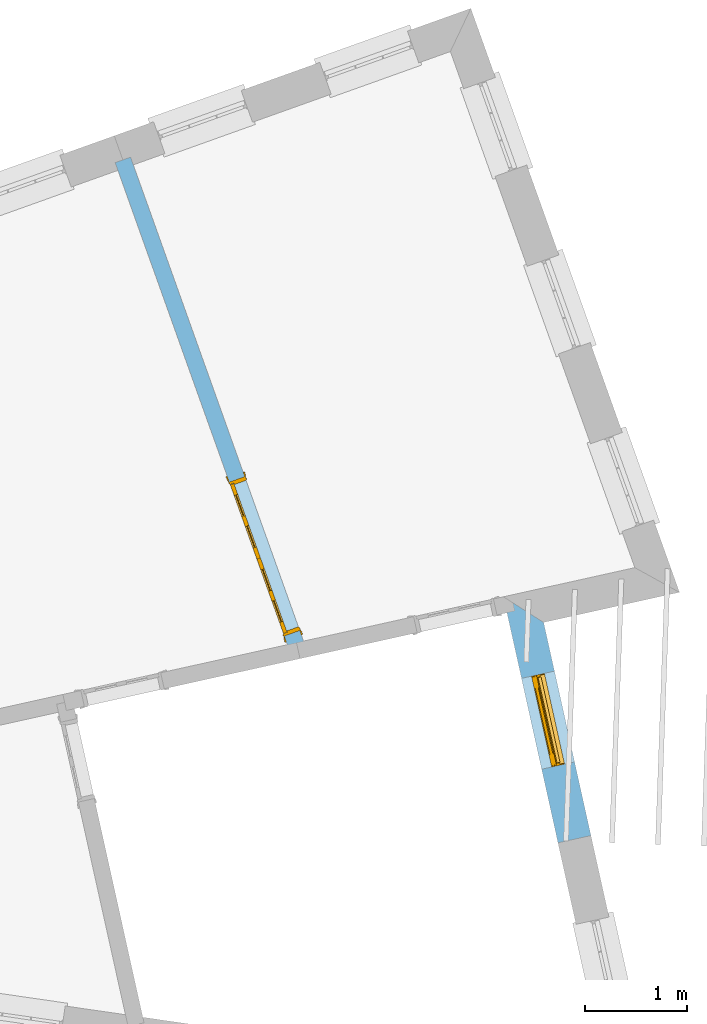
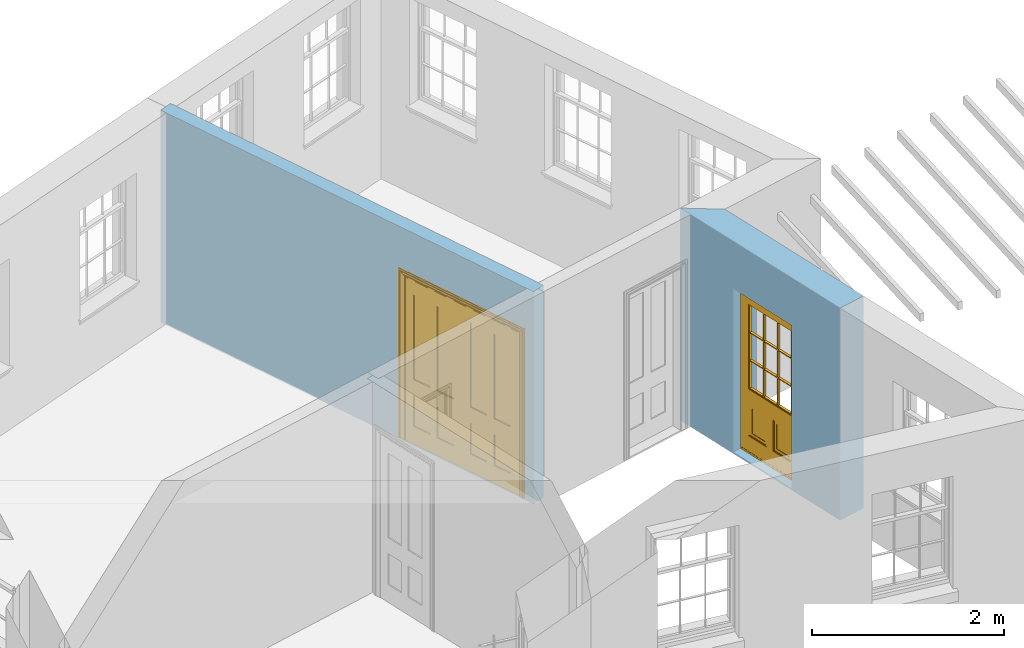
# One storey, part 7 of 11: 2 doors, 2 openings, plus 2 elements that do not belong to this part.
"""IFC2X3 building model written with IfcOpenShell, lengths in metres."""

from ifc_helpers import new_model, si_unit, frame, origin, place, context, subcontext, project, spatial, polyline, outline, extrude, faceted_brep, material, layer, layer_set, layer_usage, element, fill, save


model = new_model("IFC2X3")

# Units and contexts
model_context = context("Model", 3, world=origin())
body_context = subcontext(model_context, "Body", "Model", "MODEL_VIEW")
ifc_project = project(units=[si_unit("PLANEANGLEUNIT", "RADIAN"), si_unit("MASSUNIT", "GRAM", prefix="KILO"), si_unit("FORCEUNIT", "NEWTON", prefix="KILO"), si_unit("LENGTHUNIT", "METRE")], contexts=[model_context])

# Site, building, storey
site_placement = place(None, origin())
site = spatial("IfcSite", under=ifc_project, at=site_placement, CompositionType="ELEMENT")
building_placement = place(None, origin())
building = spatial("IfcBuilding", under=site, at=building_placement, Name="Building plot-16", CompositionType="ELEMENT")
storey_placement = place(None, frame((0.0, 0.0, 9.0)))
storey = spatial("IfcBuildingStorey", under=building, at=storey_placement, Name="Floor 2", CompositionType="ELEMENT", Elevation=9.0)

# Wall, opening, door
ifc_material_1 = material(Name="Masonry")
ifc_layer_1 = layer(ifc_material_1, 0.33, ventilated=False)
ifc_layer_set_1 = layer_set([ifc_layer_1], Name="My Wall")
ifc_layer_usage_1 = layer_usage(ifc_layer_set_1, "AXIS2", "NEGATIVE", 0.08)
wall_1_placement = place(storey_placement, origin())
wall_1 = element("IfcWallStandardCase", 1, at=wall_1_placement, inside=storey, material=ifc_layer_usage_1, Name="exterior", context=body_context, shape_type="SweptSolid", body=[
    extrude(outline(polyline([(96.6294918891393, 33.110627952855), (96.9516649800753, 33.1820737328336), (96.4893931799692, 35.2666130119531), (96.0957743090546, 35.5173403229106), (96.6294918891393, 33.110627952855)])), origin(), (0.0, 0.0, 1.0), 2.7),
])
opening_1_placement = place(storey_placement, frame((0.0, 0.0, 0.0199999999999996)))
opening_1 = element("IfcOpeningElement", 2, at=opening_1_placement, cuts=wall_1, Name="Opening", ObjectType="Opening", context=body_context, shape_type="SweptSolid", body=[
    extrude(outline(polyline([(96.7919748600008, 33.9021702814574), (96.5949577091508, 34.7905869867657), (96.2727846182148, 34.7191412067871), (96.4698017690648, 33.8307245014788), (96.7919748600008, 33.9021702814574)])), origin(), (0.0, 0.0, 1.0), 2.08),
])
door_1_placement = place(storey_placement, frame((96.5479043365645, 33.8480446905645, 0.0199999999999996), z_axis=(0.0, 0.0, 1.0), x_axis=(-0.197017150850044, 0.888416705308344, 0.0)))
door_1 = element("IfcDoor", 3, at=door_1_placement, inside=storey, Name="circulation outside door", OverallHeight=2.08, OverallWidth=0.91, context=body_context, shape_type="Brep", held_by="IfcProductRepresentation", body=[
    faceted_brep([(0.545, -0.055, 0.265), (0.745, -0.055, 0.265), (0.745, -0.05, 0.265), (0.545, -0.05, 0.265), (0.745, -0.05, 0.58), (0.545, -0.05, 0.58), (0.545, -0.055, 0.58), (0.515, -0.06, 0.235), (0.775, -0.06, 0.235), (0.745, -0.055, 0.58), (0.515, -0.06, 0.61), (0.515, -0.065, 0.235), (0.775, -0.065, 0.235), (0.775, -0.06, 0.61), (0.515, -0.065, 0.61), (0.785, -0.065, 0.225), (0.505, -0.065, 0.225), (0.775, -0.065, 0.61), (0.505, -0.065, 0.62), (0.785, -0.065, 0.62), (0.505, -0.07, 0.225), (0.785, -0.07, 0.225), (0.505, -0.07, 0.62), (0.785, -0.07, 0.62), (0.883, -0.07, 0.075), (0.898, -0.07, 0.075), (0.405, -0.07, 0.62), (0.405, -0.07, 0.225), (0.027, -0.07, 0.075), (0.785, -0.07, 0.82), (0.125, -0.07, 0.82), (0.405, -0.065, 0.62), (0.405, -0.065, 0.225), (0.898, -0.07, 2.068), (0.027, -0.08, 0.075), (0.883, -0.08, 0.075), (0.125, -0.07, 0.225), (0.012, -0.07, 0.075), (0.785, -0.06, 0.82), (0.125, -0.06, 0.82), (0.125, -0.07, 0.62), (0.125, -0.065, 0.62), (0.395, -0.065, 0.61), (0.395, -0.065, 0.235), (0.125, -0.065, 0.225), (0.785, -0.07, 1.895), (0.027, -0.11, 0.045), (0.883, -0.11, 0.045), (0.558333, -0.06, 0.83), (0.351667, -0.06, 0.83), (0.125, -0.07, 1.895), (0.125, -0.06, 1.895), (0.785, -0.06, 1.895), (0.012, -0.07, 2.068), (0.135, -0.065, 0.61), (0.395, -0.06, 0.61), (0.395, -0.06, 0.235), (0.135, -0.065, 0.235), (0.027, -0.11, 0.027), (0.883, -0.11, 0.027), (0.568333, -0.06, 0.83), (0.558333, -0.03, 0.83), (0.351667, -0.03, 0.83), (0.341667, -0.06, 0.83), (0.135, -0.06, 1.185), (0.135, -0.06, 1.53), (0.775, -0.06, 1.53), (0.775, -0.06, 1.185), (0.135, -0.06, 0.61), (0.365, -0.055, 0.58), (0.365, -0.055, 0.265), (0.135, -0.06, 0.235), (0.568333, -0.06, 1.175), (0.558333, -0.06, 1.175), (0.775, -0.06, 0.83), (0.558333, -0.03, 1.175), (0.785, -0.03, 0.82), (0.125, -0.03, 0.82), (0.351667, -0.03, 1.175), (0.351667, -0.06, 1.175), (0.341667, -0.06, 1.175), (0.135, -0.06, 0.83), (0.135, -0.06, 1.175), (0.135, -0.03, 1.185), (0.135, -0.03, 1.53), (0.135, -0.06, 1.54), (0.351667, -0.06, 1.885), (0.558333, -0.06, 1.885), (0.775, -0.03, 1.53), (0.775, -0.03, 1.185), (0.775, -0.06, 1.175), (0.775, -0.06, 1.54), (0.165, -0.055, 0.58), (0.365, -0.05, 0.58), (0.365, -0.05, 0.265), (0.165, -0.055, 0.265), (0.568333, -0.03, 0.83), (0.568333, -0.03, 1.175), (0.568333, -0.06, 1.185), (0.558333, -0.06, 1.185), (0.775, -0.03, 0.83), (0.785, -0.02, 0.82), (0.125, -0.02, 0.82), (0.341667, -0.03, 0.83), (0.341667, -0.03, 1.175), (0.351667, -0.06, 1.185), (0.341667, -0.06, 1.185), (0.135, -0.03, 0.83), (0.341667, -0.03, 1.185), (0.125, -0.03, 1.895), (0.341667, -0.03, 1.53), (0.341667, -0.06, 1.53), (0.135, -0.06, 1.885), (0.341667, -0.06, 1.54), (0.341667, -0.06, 1.885), (0.558333, -0.03, 1.885), (0.351667, -0.03, 1.885), (0.568333, -0.06, 1.885), (0.785, -0.03, 1.895), (0.568333, -0.03, 1.185), (0.568333, -0.06, 1.53), (0.568333, -0.03, 1.53), (0.568333, -0.06, 1.54), (0.775, -0.06, 1.885), (0.165, -0.05, 0.58), (0.165, -0.05, 0.265), (0.775, -0.03, 1.175), (0.558333, -0.06, 1.53), (0.351667, -0.03, 1.185), (0.558333, -0.03, 1.185), (0.505, -0.02, 0.62), (0.405, -0.02, 0.62), (0.125, -0.02, 1.895), (0.785, -0.02, 1.895), (0.351667, -0.06, 1.53), (0.135, -0.03, 1.175), (0.135, -0.03, 1.54), (0.341667, -0.03, 1.54), (0.135, -0.03, 1.885), (0.351667, -0.06, 1.54), (0.558333, -0.03, 1.54), (0.558333, -0.06, 1.54), (0.351667, -0.03, 1.54), (0.775, -0.03, 1.54), (0.568333, -0.03, 1.54), (0.775, -0.03, 1.885), (0.558333, -0.03, 1.53), (0.405, -0.02, 0.225), (0.505, -0.02, 0.225), (0.125, -0.02, 0.62), (0.785, -0.02, 0.62), (0.012, -0.02, 2.068), (0.898, -0.02, 2.068), (0.351667, -0.03, 1.53), (0.341667, -0.03, 1.885), (0.568333, -0.03, 1.885), (0.405, -0.025, 0.225), (0.405, -0.025, 0.62), (0.505, -0.025, 0.62), (0.505, -0.025, 0.225), (0.898, -0.02, 0.027), (0.012, -0.02, 0.027), (0.125, -0.025, 0.62), (0.785, -0.025, 0.62), (0.395, -0.025, 0.235), (0.395, -0.025, 0.61), (0.125, -0.02, 0.225), (0.125, -0.025, 0.225), (0.515, -0.025, 0.61), (0.515, -0.025, 0.235), (0.785, -0.02, 0.225), (0.785, -0.025, 0.225), (0.135, -0.025, 0.61), (0.775, -0.025, 0.61), (0.135, -0.025, 0.235), (0.395, -0.03, 0.235), (0.395, -0.03, 0.61), (0.515, -0.03, 0.61), (0.515, -0.03, 0.235), (0.775, -0.025, 0.235), (0.135, -0.03, 0.61), (0.775, -0.03, 0.61), (0.135, -0.03, 0.235), (0.365, -0.035, 0.265), (0.365, -0.035, 0.58), (0.545, -0.035, 0.58), (0.545, -0.035, 0.265), (0.775, -0.03, 0.235), (0.165, -0.035, 0.58), (0.745, -0.035, 0.58), (0.165, -0.035, 0.265), (0.365, -0.04, 0.58), (0.365, -0.04, 0.265), (0.545, -0.04, 0.58), (0.545, -0.04, 0.265), (0.745, -0.035, 0.265), (0.165, -0.04, 0.58), (0.745, -0.04, 0.58), (0.165, -0.04, 0.265), (0.745, -0.04, 0.265), (0.885, -0.072, 0.025), (0.025, -0.072, 0.025), (0.025, -0.1, 0.025), (0.885, -0.1, 0.025), (0.9, -0.02, 0.025), (0.01, -0.02, 0.025), (0.9, -0.072, 0.025), (0.91, -0.02, 0.0), (0.0, -0.02, 0.0), (0.01, -0.072, 0.025), (0.9, -0.072, 2.07), (0.9, -0.02, 2.07), (0.885, -0.072, 2.055), (0.91, -0.02, 2.08), (0.01, -0.02, 2.07), (0.0, -0.02, 2.08), (0.01, -0.072, 2.07), (0.025, -0.072, 2.055), (0.0, -0.15, 2.08), (0.91, -0.15, 2.08), (0.01, -0.15, 2.07), (0.9, -0.15, 2.07), (0.01, -0.1, 2.07), (0.9, -0.1, 2.07), (0.0, -0.15, 0.0), (0.91, -0.15, 0.0), (0.01, -0.15, 0.025), (0.9, -0.15, 0.025), (0.01, -0.1, 0.025), (0.025, -0.1, 2.055), (0.9, -0.1, 0.025), (0.885, -0.1, 2.055), (0.898, -0.07, 0.027), (0.012, -0.07, 0.027), (0.883, -0.07, 0.027), (0.027, -0.07, 0.027)], [[[0, 1, 2, 3]], [[2, 4, 5, 3]], [[0, 3, 5, 6]], [[1, 0, 7, 8]], [[9, 4, 2, 1]], [[9, 6, 5, 4]], [[0, 6, 10, 7]], [[8, 7, 11, 12]], [[8, 13, 9, 1]], [[13, 10, 6, 9]], [[7, 10, 14, 11]], [[15, 12, 11, 16]], [[12, 17, 13, 8]], [[17, 14, 10, 13]], [[18, 16, 11, 14]], [[15, 19, 17, 12]], [[15, 16, 20, 21]], [[14, 17, 19, 18]], [[16, 18, 22, 20]], [[21, 23, 19, 15]], [[24, 25, 21, 20]], [[23, 22, 18, 19]], [[20, 22, 26, 27]], [[23, 21, 25]], [[28, 24, 20, 27]], [[22, 23, 29]], [[29, 30, 26, 22]], [[27, 26, 31, 32]], [[23, 25, 33, 29]], [[34, 35, 24, 28]], [[28, 27, 36, 37]], [[38, 39, 30, 29]], [[26, 30, 40]], [[26, 40, 41, 31]], [[42, 43, 32, 31]], [[32, 44, 36, 27]], [[33, 45, 29]], [[46, 47, 35, 34]], [[36, 40, 37]], [[39, 38, 48, 49]], [[50, 30, 39, 51]], [[29, 45, 52, 38]], [[53, 37, 40, 30]], [[44, 41, 40, 36]], [[31, 41, 54, 42]], [[43, 42, 55, 56]], [[57, 44, 32, 43]], [[50, 45, 33, 53]], [[47, 46, 58, 59]], [[60, 48, 38]], [[49, 48, 61, 62]], [[49, 63, 39]], [[50, 53, 30]], [[51, 39, 64, 65]], [[45, 50, 51, 52]], [[66, 67, 38, 52]], [[57, 54, 41, 44]], [[42, 54, 68, 55]], [[56, 55, 69, 70]], [[56, 71, 57, 43]], [[60, 72, 73, 48]], [[60, 38, 74]], [[48, 73, 75, 61]], [[76, 77, 62, 61]], [[62, 78, 79, 49]], [[49, 79, 80, 63]], [[63, 81, 39]], [[82, 64, 39]], [[65, 64, 83, 84]], [[85, 51, 65]], [[52, 51, 86, 87]], [[88, 89, 67, 66]], [[90, 38, 67]], [[91, 66, 52]], [[71, 68, 54, 57]], [[55, 68, 92, 69]], [[69, 93, 94, 70]], [[70, 95, 71, 56]], [[96, 97, 72, 60]], [[73, 72, 98, 99]], [[74, 38, 90]], [[100, 96, 60, 74]], [[75, 73, 79, 78]], [[61, 75, 97, 96]], [[101, 102, 77, 76]], [[77, 103, 62]], [[96, 76, 61]], [[103, 104, 78, 62]], [[80, 79, 105, 106]], [[63, 80, 104, 103]], [[81, 63, 103, 107]], [[81, 82, 39]], [[106, 64, 82, 80]], [[106, 108, 83, 64]], [[84, 83, 77, 109]], [[110, 111, 65, 84]], [[112, 51, 85]], [[113, 85, 65, 111]], [[114, 86, 51]], [[115, 87, 86, 116]], [[117, 52, 87]], [[118, 76, 89, 88]], [[119, 98, 67, 89]], [[120, 121, 88, 66]], [[67, 98, 72, 90]], [[91, 122, 120, 66]], [[91, 52, 123]], [[95, 92, 68, 71]], [[69, 92, 124, 93]], [[94, 93, 124, 125]], [[94, 125, 95, 70]], [[72, 97, 126, 90]], [[127, 99, 98, 120]], [[99, 105, 79, 73]], [[74, 90, 126, 100]], [[96, 100, 76]], [[128, 129, 75, 78]], [[97, 75, 129, 119]], [[130, 131, 102, 101]], [[109, 77, 102, 132]], [[133, 101, 76, 118]], [[77, 107, 103]], [[78, 104, 108, 128]], [[111, 106, 105, 134]], [[104, 80, 82, 135]], [[107, 135, 82, 81]], [[110, 108, 106, 111]], [[104, 135, 83, 108]], [[83, 135, 77]], [[136, 84, 109]], [[110, 84, 136, 137]], [[114, 51, 112]], [[85, 136, 138, 112]], [[113, 137, 136, 85]], [[111, 134, 139, 113]], [[86, 114, 113, 139]], [[140, 141, 87, 115]], [[139, 142, 116, 86]], [[109, 118, 115, 116]], [[117, 123, 52]], [[117, 87, 141, 122]], [[126, 89, 76]], [[143, 118, 88]], [[120, 98, 119, 121]], [[119, 89, 126, 97]], [[144, 143, 88, 121]], [[144, 122, 91, 143]], [[127, 120, 122, 141]], [[143, 91, 123, 145]], [[124, 92, 95, 125]], [[146, 129, 99, 127]], [[99, 129, 128, 105]], [[100, 126, 76]], [[121, 119, 129, 146]], [[147, 131, 130, 148]], [[131, 149, 102]], [[130, 101, 150]], [[102, 151, 132]], [[118, 109, 132, 133]], [[101, 133, 152]], [[107, 77, 135]], [[153, 128, 108, 110]], [[134, 105, 128, 153]], [[109, 138, 136]], [[153, 110, 137, 142]], [[154, 114, 112, 138]], [[137, 113, 114, 154]], [[141, 139, 134, 127]], [[141, 140, 142, 139]], [[144, 140, 115, 155]], [[142, 137, 154, 116]], [[155, 115, 118]], [[116, 154, 109]], [[117, 155, 145, 123]], [[122, 144, 155, 117]], [[143, 145, 118]], [[121, 146, 140, 144]], [[146, 127, 134, 153]], [[156, 157, 131, 147]], [[148, 130, 158, 159]], [[148, 160, 161, 147]], [[157, 162, 149, 131]], [[161, 151, 102, 149]], [[101, 152, 160, 150]], [[163, 158, 130, 150]], [[151, 152, 133, 132]], [[154, 138, 109]], [[142, 140, 146, 153]], [[145, 155, 118]], [[157, 156, 164, 165]], [[147, 166, 167, 156]], [[168, 169, 159, 158]], [[170, 148, 159, 171]], [[148, 170, 160]], [[166, 147, 161]], [[172, 162, 157, 165]], [[166, 149, 162, 167]], [[166, 161, 149]], [[150, 160, 170]], [[163, 173, 168, 158]], [[171, 163, 150, 170]], [[174, 164, 156, 167]], [[175, 176, 165, 164]], [[169, 168, 177, 178]], [[171, 159, 169, 179]], [[167, 162, 172, 174]], [[176, 180, 172, 165]], [[179, 173, 163, 171]], [[181, 177, 168, 173]], [[164, 174, 182, 175]], [[183, 184, 176, 175]], [[178, 177, 185, 186]], [[179, 169, 178, 187]], [[174, 172, 180, 182]], [[184, 188, 180, 176]], [[187, 181, 173, 179]], [[189, 185, 177, 181]], [[175, 182, 190, 183]], [[191, 184, 183, 192]], [[185, 193, 194, 186]], [[187, 178, 186, 195]], [[182, 180, 188, 190]], [[191, 196, 188, 184]], [[195, 189, 181, 187]], [[197, 193, 185, 189]], [[183, 190, 198, 192]], [[198, 196, 191, 192]], [[194, 193, 197, 199]], [[195, 186, 194, 199]], [[188, 196, 198, 190]], [[197, 189, 195, 199]], [[200, 201, 202, 203]], [[201, 200, 204, 205]], [[206, 204, 200]], [[204, 207, 208, 205]], [[209, 201, 205]], [[210, 211, 204, 206]], [[206, 200, 212, 210]], [[211, 213, 207, 204]], [[214, 205, 208, 215]], [[216, 217, 201, 209]], [[205, 214, 216, 209]], [[216, 214, 211, 210]], [[210, 212, 217, 216]], [[214, 215, 213, 211]], [[218, 219, 213, 215]], [[219, 218, 220, 221]], [[221, 220, 222, 223]], [[215, 208, 224, 218]], [[225, 224, 208, 207]], [[224, 226, 220, 218]], [[224, 225, 227, 226]], [[219, 225, 207, 213]], [[228, 222, 220, 226]], [[219, 221, 227, 225]], [[226, 227, 203, 202]], [[202, 229, 222, 228]], [[228, 226, 202]], [[227, 221, 223, 230]], [[230, 203, 227]], [[217, 229, 202, 201]], [[231, 223, 222, 229]], [[230, 223, 231, 203]], [[231, 229, 217, 212]], [[212, 200, 203, 231]], [[33, 152, 151, 53]], [[25, 160, 152, 33]], [[161, 37, 53, 151]], [[232, 160, 25]], [[161, 233, 37]], [[160, 232, 234]], [[24, 234, 232, 25]], [[233, 161, 235]], [[37, 233, 235, 28]], [[161, 160, 234, 235]], [[35, 47, 234, 24]], [[28, 235, 46, 34]], [[58, 235, 234, 59]], [[59, 234, 47]], [[58, 46, 235]]]),
])
fill(opening_1, door_1)

ifc_material_2 = material(Name="Masonry")
ifc_layer_2 = layer(ifc_material_2, 0.16, ventilated=False)
ifc_layer_set_2 = layer_set([ifc_layer_2], Name="My Wall")
ifc_layer_usage_2 = layer_usage(ifc_layer_set_2, "AXIS2", "NEGATIVE", 0.08)
wall_2_placement = place(storey_placement, origin())
wall_2 = element("IfcWallStandardCase", 4, at=wall_2_placement, inside=storey, material=ifc_layer_usage_2, Name="interior", context=body_context, shape_type="SweptSolid", body=[
    extrude(outline(polyline([(94.0135349523294, 34.9634200632447), (94.1642034180616, 35.0172625505007), (92.4487673338736, 39.8176002770463), (92.2980988681414, 39.7637577897903), (94.0135349523294, 34.9634200632447)])), origin(), (0.0, 0.0, 1.0), 2.7),
])
opening_2_placement = place(storey_placement, frame((0.0, 0.0, 0.0199999999999996)))
opening_2 = element("IfcOpeningElement", 5, at=opening_2_placement, cuts=wall_2, Name="Opening", ObjectType="Opening", context=body_context, shape_type="SweptSolid", body=[
    extrude(outline(polyline([(94.1036306198986, 35.1867645744494), (93.5652057473382, 36.693449231771), (93.414537281606, 36.639606744515), (93.9529621541664, 35.1329220871934), (94.1036306198986, 35.1867645744494)])), origin(), (0.0, 0.0, 1.0), 2.1),
])
door_2_placement = place(storey_placement, frame((94.0282963870325, 35.1598433308214, 0.0199999999999996), z_axis=(0.0, 0.0, 1.0), x_axis=(-0.538424872560356, 1.50668465732162, 0.0)))
door_2 = element("IfcDoor", 6, at=door_2_placement, inside=storey, Name="kitchen living inside door", OverallHeight=2.1, OverallWidth=1.6, context=body_context, shape_type="Brep", held_by="IfcProductRepresentation", body=[
    faceted_brep([(0.14, 0.057, 1.895), (0.14, 0.057, 0.82), (0.363, 0.057, 0.82), (0.363, 0.057, 1.895), (0.14, 0.042, 1.895), (0.14, 0.042, 0.82), (0.363, 0.042, 0.82), (0.363, 0.042, 1.895), (0.027, 0.042, 1.895), (0.027, 0.042, 0.82), (0.363, 0.042, 0.62), (0.14, 0.042, 0.62), (0.463, 0.042, 0.82), (0.463, 0.042, 1.895), (0.363, 0.042, 2.073), (0.14, 0.042, 2.073), (0.027, 0.042, 2.073), (0.027, 0.08, 1.895), (0.027, 0.08, 0.82), (0.027, 0.042, 0.62), (0.463, 0.042, 0.62), (0.14, 0.057, 0.62), (0.363, 0.057, 0.62), (0.463, 0.057, 0.82), (0.463, 0.057, 1.895), (0.463, 0.042, 2.073), (0.14, 0.08, 2.073), (0.363, 0.08, 2.073), (0.027, 0.08, 2.073), (0.14, 0.08, 1.895), (0.14, 0.08, 0.82), (0.027, 0.08, 0.62), (0.027, 0.042, 0.225), (0.14, 0.042, 0.225), (0.363, 0.042, 0.225), (0.463, 0.042, 0.225), (0.686, 0.042, 0.62), (0.686, 0.042, 0.82), (0.14, 0.057, 0.225), (0.363, 0.057, 0.225), (0.686, 0.057, 0.82), (0.686, 0.057, 1.895), (0.686, 0.042, 1.895), (0.686, 0.042, 2.073), (0.463, 0.08, 2.073), (0.363, 0.08, 1.895), (0.14, 0.065, 1.895), (0.14, 0.065, 0.82), (0.14, 0.08, 0.62), (0.027, 0.08, 0.225), (0.027, 0.042, 0.0), (0.14, 0.042, 0.0), (0.363, 0.042, 0.0), (0.463, 0.042, 0.0), (0.463, 0.057, 0.225), (0.463, 0.057, 0.62), (0.686, 0.057, 0.62), (0.799, 0.042, 0.62), (0.799, 0.042, 0.82), (0.799, 0.042, 1.895), (0.799, 0.042, 2.073), (0.686, 0.08, 2.073), (0.463, 0.08, 1.895), (0.363, 0.065, 1.895), (0.363, 0.065, 0.82), (0.363, 0.08, 0.82), (0.363, 0.08, 0.62), (0.14, 0.08, 0.225), (0.027, 0.08, 0.0), (0.14, 0.08, 0.0), (0.363, 0.08, 0.0), (0.463, 0.08, 0.0), (0.686, 0.042, 0.0), (0.686, 0.042, 0.225), (0.686, 0.057, 0.225), (0.799, 0.042, 0.225), (0.799, 0.08, 0.62), (0.799, 0.08, 0.82), (0.799, 0.08, 1.895), (0.799, 0.08, 2.073), (0.686, 0.08, 1.895), (0.463, 0.08, 0.82), (0.463, 0.08, 0.62), (0.363, 0.065, 0.62), (0.14, 0.065, 0.62), (0.14, 0.065, 0.225), (0.363, 0.08, 0.225), (0.463, 0.08, 0.225), (0.686, 0.08, 0.0), (0.799, 0.042, 0.0), (0.799, 0.08, 0.225), (0.686, 0.08, 0.62), (0.686, 0.08, 0.82), (0.686, 0.065, 1.895), (0.463, 0.065, 1.895), (0.463, 0.065, 0.82), (0.363, 0.065, 0.225), (0.686, 0.08, 0.225), (0.799, 0.08, 0.0), (0.686, 0.065, 0.82), (0.463, 0.065, 0.62), (0.463, 0.065, 0.225), (0.686, 0.065, 0.62), (0.686, 0.065, 0.225), (1.46, 0.08, 1.895), (1.237, 0.08, 1.895), (1.237, 0.08, 2.073), (1.46, 0.08, 2.073), (1.46, 0.065, 1.895), (1.237, 0.065, 1.895), (1.137, 0.08, 1.895), (1.137, 0.08, 2.073), (1.237, 0.042, 2.073), (1.46, 0.042, 2.073), (1.573, 0.08, 1.895), (1.573, 0.08, 2.073), (1.46, 0.08, 0.82), (1.46, 0.065, 0.82), (1.237, 0.065, 0.82), (1.237, 0.08, 0.82), (1.137, 0.08, 0.82), (0.914, 0.08, 2.073), (0.914, 0.08, 1.895), (1.137, 0.042, 2.073), (1.237, 0.042, 1.895), (1.46, 0.042, 1.895), (1.573, 0.042, 2.073), (1.573, 0.08, 0.82), (1.573, 0.042, 1.895), (1.237, 0.08, 0.62), (1.137, 0.08, 0.62), (1.137, 0.065, 0.82), (1.137, 0.065, 1.895), (0.914, 0.042, 2.073), (0.914, 0.065, 1.895), (0.801, 0.08, 2.073), (0.801, 0.08, 1.895), (1.137, 0.042, 1.895), (1.237, 0.057, 1.895), (1.46, 0.057, 1.895), (1.573, 0.042, 0.82), (1.573, 0.08, 0.62), (1.46, 0.08, 0.62), (1.237, 0.08, 0.225), (1.137, 0.08, 0.225), (0.914, 0.08, 0.82), (0.914, 0.08, 0.62), (0.914, 0.065, 0.82), (0.801, 0.042, 2.073), (0.914, 0.042, 1.895), (0.801, 0.08, 0.82), (0.801, 0.042, 1.895), (1.137, 0.042, 0.82), (1.237, 0.042, 0.82), (1.237, 0.057, 0.82), (1.46, 0.057, 0.82), (1.46, 0.042, 0.82), (1.573, 0.042, 0.62), (1.573, 0.08, 0.225), (1.46, 0.08, 0.225), (1.46, 0.065, 0.62), (1.237, 0.065, 0.62), (1.237, 0.08, 0.0), (1.137, 0.08, 0.0), (1.137, 0.065, 0.225), (1.137, 0.065, 0.62), (1.237, 0.065, 0.225), (0.914, 0.065, 0.62), (0.801, 0.08, 0.62), (0.914, 0.057, 1.895), (1.137, 0.057, 1.895), (0.801, 0.042, 0.82), (1.137, 0.042, 0.62), (1.237, 0.042, 0.62), (1.137, 0.057, 0.82), (1.46, 0.042, 0.62), (1.573, 0.042, 0.225), (1.573, 0.08, 0.0), (1.46, 0.08, 0.0), (1.46, 0.065, 0.225), (1.237, 0.042, 0.0), (1.137, 0.042, 0.0), (0.914, 0.08, 0.225), (0.914, 0.08, 0.0), (0.914, 0.065, 0.225), (0.801, 0.08, 0.225), (0.801, 0.042, 0.62), (0.914, 0.042, 0.82), (0.914, 0.057, 0.82), (1.137, 0.042, 0.225), (1.237, 0.042, 0.225), (0.914, 0.042, 0.62), (1.46, 0.042, 0.225), (1.573, 0.042, 0.0), (1.46, 0.042, 0.0), (0.914, 0.042, 0.0), (0.801, 0.08, 0.0), (0.801, 0.042, 0.225), (1.237, 0.057, 0.225), (1.237, 0.057, 0.62), (1.137, 0.057, 0.62), (1.137, 0.057, 0.225), (1.46, 0.057, 0.62), (0.914, 0.057, 0.62), (1.46, 0.057, 0.225), (0.914, 0.042, 0.225), (0.801, 0.042, 0.0), (0.914, 0.057, 0.225), (0.02, 0.085, 0.0), (0.005, 0.09, 0.0), (0.005, 0.09, 2.095), (0.02, 0.085, 2.08), (0.02, 0.08, 0.0), (0.0, 0.085, 0.0), (0.0, 0.085, 2.1), (1.595, 0.09, 2.095), (1.58, 0.085, 2.08), (0.02, 0.08, 2.08), (0.0, 0.08, 0.0), (-0.032, 0.095, 0.0), (-0.032, 0.095, 2.132), (1.6, 0.085, 2.1), (1.595, 0.09, 0.0), (1.58, 0.085, 0.0), (1.58, 0.08, 2.08), (0.025, 0.08, 0.0), (0.025, 0.08, 2.075), (-0.04, 0.09, 0.0), (0.025, 0.04, 0.0), (0.0, -0.08, 0.0), (-0.04, 0.09, 2.14), (1.632, 0.095, 2.132), (1.6, 0.085, 0.0), (1.58, 0.08, 0.0), (1.575, 0.08, 2.075), (0.025, 0.04, 2.075), (-0.06, 0.08, 0.0), (0.035, -0.08, 0.0), (0.0, -0.08, 2.1), (0.0, 0.08, 2.1), (-0.04, 0.095, 0.0), (-0.04, 0.095, 2.14), (1.64, 0.09, 2.14), (1.632, 0.095, 0.0), (1.6, 0.08, 0.0), (1.575, 0.08, 0.0), (1.575, 0.04, 2.075), (0.04, 0.04, 0.0), (0.04, 0.04, 2.06), (-0.06, 0.095, 0.0), (-0.06, 0.08, 2.16), (0.015, -0.085, 0.0), (0.04, -0.08, 0.0), (-0.045, -0.08, 2.145), (-0.045, -0.08, 0.0), (1.6, -0.08, 2.1), (1.6, 0.08, 2.1), (-0.06, 0.095, 2.16), (1.64, 0.095, 2.14), (1.64, 0.09, 0.0), (1.6, -0.08, 0.0), (1.575, 0.04, 0.0), (1.56, 0.04, 2.06), (0.04, -0.08, 2.06), (1.66, 0.08, 2.16), (-0.017, -0.095, 0.0), (-0.025, -0.09, 0.0), (0.02, -0.09, 0.0), (0.035, -0.085, 0.0), (0.035, -0.08, 2.065), (1.645, -0.08, 2.145), (-0.045, -0.095, 2.145), (-0.045, -0.095, 0.0), (1.66, 0.095, 2.16), (1.64, 0.095, 0.0), (1.66, 0.08, 0.0), (1.565, -0.08, 0.0), (1.56, 0.04, 0.0), (1.56, -0.08, 2.06), (-0.017, -0.095, 2.117), (-0.025, -0.09, 2.125), (0.015, -0.085, 2.085), (0.02, -0.09, 2.08), (0.035, -0.085, 2.065), (1.565, -0.08, 2.065), (1.645, -0.08, 0.0), (1.645, -0.095, 2.145), (-0.025, -0.095, 0.0), (1.66, 0.095, 0.0), (1.585, -0.085, 0.0), (1.56, -0.08, 0.0), (1.617, -0.095, 2.117), (1.625, -0.09, 2.125), (-0.025, -0.095, 2.125), (1.585, -0.085, 2.085), (1.58, -0.09, 2.08), (1.565, -0.085, 2.065), (1.625, -0.09, 0.0), (1.645, -0.095, 0.0), (1.625, -0.095, 2.125), (1.617, -0.095, 0.0), (1.565, -0.085, 0.0), (1.58, -0.09, 0.0), (1.625, -0.095, 0.0)], [[[0, 1, 2, 3]], [[1, 0, 4, 5]], [[2, 1, 5, 6]], [[6, 7, 3, 2]], [[7, 4, 0, 3]], [[4, 8, 9, 5]], [[10, 6, 5, 11]], [[6, 12, 13, 7]], [[14, 15, 4, 7]], [[15, 16, 8, 4]], [[9, 8, 17, 18]], [[5, 9, 19, 11]], [[10, 20, 12, 6]], [[10, 11, 21, 22]], [[13, 12, 23, 24]], [[7, 13, 25, 14]], [[26, 15, 14, 27]], [[28, 16, 15, 26]], [[8, 16, 28, 17]], [[17, 29, 30, 18]], [[18, 31, 19, 9]], [[11, 19, 32, 33]], [[34, 35, 20, 10]], [[20, 36, 37, 12]], [[11, 33, 38, 21]], [[39, 22, 21, 38]], [[34, 10, 22, 39]], [[12, 37, 40, 23]], [[24, 23, 40, 41]], [[42, 13, 24, 41]], [[13, 42, 43, 25]], [[14, 25, 44, 27]], [[26, 27, 45, 29]], [[28, 26, 29, 17]], [[30, 29, 46, 47]], [[18, 30, 48, 31]], [[31, 49, 32, 19]], [[33, 32, 50, 51]], [[52, 53, 35, 34]], [[20, 35, 54, 55]], [[36, 20, 55, 56]], [[36, 57, 58, 37]], [[33, 34, 39, 38]], [[37, 42, 41, 40]], [[42, 59, 60, 43]], [[44, 25, 43, 61]], [[62, 45, 27, 44]], [[29, 45, 63, 46]], [[46, 63, 64, 47]], [[65, 30, 47, 64]], [[30, 65, 66, 48]], [[31, 48, 67, 49]], [[68, 50, 32, 49]], [[68, 69, 51, 50]], [[34, 33, 51, 52]], [[53, 52, 70, 71]], [[53, 72, 73, 35]], [[35, 73, 74, 54]], [[55, 54, 74, 56]], [[73, 36, 56, 74]], [[73, 75, 57, 36]], [[57, 76, 77, 58]], [[37, 58, 59, 42]], [[78, 79, 60, 59]], [[60, 79, 61, 43]], [[80, 62, 44, 61]], [[81, 65, 45, 62]], [[45, 65, 64, 63]], [[82, 66, 65, 81]], [[48, 66, 83, 84]], [[67, 48, 84, 85]], [[49, 67, 69, 68]], [[52, 51, 69, 70]], [[71, 70, 86, 87]], [[72, 53, 71, 88]], [[72, 89, 75, 73]], [[75, 90, 76, 57]], [[76, 91, 92, 77]], [[78, 59, 58, 77]], [[78, 80, 61, 79]], [[62, 80, 93, 94]], [[81, 62, 94, 95]], [[87, 86, 66, 82]], [[91, 82, 81, 92]], [[66, 86, 96, 83]], [[84, 83, 96, 85]], [[86, 67, 85, 96]], [[67, 86, 70, 69]], [[88, 71, 87, 97]], [[89, 72, 88, 98]], [[89, 98, 90, 75]], [[90, 97, 91, 76]], [[80, 78, 77, 92]], [[80, 92, 99, 93]], [[99, 95, 94, 93]], [[92, 81, 95, 99]], [[87, 82, 100, 101]], [[82, 91, 102, 100]], [[97, 87, 101, 103]], [[98, 88, 97, 90]], [[91, 97, 103, 102]], [[103, 101, 100, 102]], [[104, 105, 106, 107]], [[105, 104, 108, 109]], [[105, 110, 111, 106]], [[106, 112, 113, 107]], [[114, 104, 107, 115]], [[104, 116, 117, 108]], [[117, 118, 109, 108]], [[119, 105, 109, 118]], [[119, 120, 110, 105]], [[121, 111, 110, 122]], [[123, 112, 106, 111]], [[124, 125, 113, 112]], [[126, 115, 107, 113]], [[104, 114, 127, 116]], [[114, 115, 126, 128]], [[116, 119, 118, 117]], [[129, 130, 120, 119]], [[110, 120, 131, 132]], [[121, 133, 123, 111]], [[122, 110, 132, 134]], [[135, 121, 122, 136]], [[137, 124, 112, 123]], [[125, 124, 138, 139]], [[125, 128, 126, 113]], [[114, 128, 140, 127]], [[141, 142, 116, 127]], [[142, 129, 119, 116]], [[143, 144, 130, 129]], [[145, 120, 130, 146]], [[120, 145, 147, 131]], [[134, 132, 131, 147]], [[135, 148, 133, 121]], [[123, 133, 149, 137]], [[145, 122, 134, 147]], [[136, 122, 145, 150]], [[151, 148, 135, 136]], [[152, 153, 124, 137]], [[124, 153, 154, 138]], [[138, 154, 155, 139]], [[156, 125, 139, 155]], [[156, 140, 128, 125]], [[157, 141, 127, 140]], [[158, 159, 142, 141]], [[129, 142, 160, 161]], [[162, 163, 144, 143]], [[130, 144, 164, 165]], [[143, 129, 161, 166]], [[146, 130, 165, 167]], [[150, 145, 146, 168]], [[133, 148, 151, 149]], [[137, 149, 169, 170]], [[171, 151, 136, 150]], [[172, 173, 153, 152]], [[152, 137, 170, 174]], [[153, 156, 155, 154]], [[175, 157, 140, 156]], [[176, 158, 141, 157]], [[177, 178, 159, 158]], [[142, 159, 179, 160]], [[179, 166, 161, 160]], [[180, 181, 163, 162]], [[182, 144, 163, 183]], [[178, 162, 143, 159]], [[144, 182, 184, 164]], [[167, 165, 164, 184]], [[159, 143, 166, 179]], [[182, 146, 167, 184]], [[168, 146, 182, 185]], [[150, 168, 186, 171]], [[149, 151, 171, 187]], [[149, 187, 188, 169]], [[169, 188, 174, 170]], [[189, 190, 173, 172]], [[173, 175, 156, 153]], [[172, 152, 187, 191]], [[187, 152, 174, 188]], [[192, 176, 157, 175]], [[193, 177, 158, 176]], [[193, 194, 178, 177]], [[181, 180, 190, 189]], [[181, 195, 183, 163]], [[194, 180, 162, 178]], [[185, 182, 183, 196]], [[168, 185, 197, 186]], [[187, 171, 186, 191]], [[173, 190, 198, 199]], [[189, 172, 200, 201]], [[175, 173, 199, 202]], [[172, 191, 203, 200]], [[194, 193, 176, 192]], [[192, 175, 202, 204]], [[180, 194, 192, 190]], [[189, 205, 195, 181]], [[196, 183, 195, 206]], [[196, 206, 197, 185]], [[191, 186, 197, 205]], [[190, 192, 204, 198]], [[199, 198, 204, 202]], [[201, 200, 203, 207]], [[205, 189, 201, 207]], [[191, 205, 207, 203]], [[205, 197, 206, 195]], [[208, 209, 210, 211]], [[208, 212, 213, 209]], [[209, 213, 214, 210]], [[211, 210, 215, 216]], [[211, 217, 212, 208]], [[218, 213, 212]], [[213, 219, 220, 214]], [[210, 214, 221, 215]], [[216, 215, 222, 223]], [[217, 211, 216, 224]], [[225, 212, 217, 226]], [[219, 213, 218, 227]], [[218, 212, 228, 229]], [[219, 227, 230, 220]], [[214, 220, 231, 221]], [[215, 221, 232, 222]], [[222, 232, 233, 223]], [[224, 216, 223, 233]], [[226, 217, 224, 234]], [[225, 228, 212]], [[235, 228, 225, 226]], [[236, 227, 218]], [[237, 229, 228]], [[229, 238, 239, 218]], [[227, 240, 241, 230]], [[220, 230, 242, 231]], [[221, 231, 243, 232]], [[244, 233, 232]], [[234, 224, 233, 245]], [[246, 235, 226, 234]], [[247, 228, 235, 248]], [[240, 227, 236, 249]], [[239, 250, 236, 218]], [[251, 229, 237]], [[252, 237, 228, 247]], [[253, 238, 229, 254]], [[238, 255, 256, 239]], [[241, 240, 257]], [[230, 241, 258, 242]], [[231, 242, 259, 243]], [[259, 244, 232, 243]], [[260, 261, 233, 244]], [[245, 233, 261]], [[261, 246, 234, 245]], [[248, 235, 246, 262]], [[248, 263, 252, 247]], [[250, 257, 249, 236]], [[240, 249, 257]], [[256, 264, 250, 239]], [[265, 266, 229, 251]], [[267, 251, 237, 268]], [[263, 269, 237, 252]], [[270, 255, 238, 253]], [[229, 266, 254]], [[271, 253, 254, 272]], [[256, 255, 260, 244]], [[273, 241, 257]], [[273, 258, 241]], [[242, 258, 274, 259]], [[275, 244, 259]], [[260, 276, 261]], [[261, 277, 262, 246]], [[262, 278, 263, 248]], [[264, 273, 257, 250]], [[244, 275, 264, 256]], [[266, 265, 279, 280]], [[265, 251, 281, 279]], [[251, 267, 282, 281]], [[269, 283, 268, 237]], [[267, 268, 283, 282]], [[278, 284, 269, 263]], [[285, 260, 255, 270]], [[286, 270, 253, 271]], [[272, 254, 266, 287]], [[271, 272, 287]], [[273, 274, 258]], [[288, 275, 259, 274]], [[276, 260, 289]], [[277, 261, 276, 290]], [[278, 262, 277, 290]], [[275, 288, 273, 264]], [[280, 279, 291, 292]], [[287, 266, 280, 293]], [[279, 281, 294, 291]], [[281, 282, 295, 294]], [[284, 296, 283, 269]], [[282, 283, 296, 295]], [[290, 276, 284, 278]], [[285, 297, 260]], [[298, 285, 270, 286]], [[299, 286, 271]], [[271, 287, 293]], [[273, 288, 274]], [[300, 289, 260, 297]], [[301, 276, 289, 302]], [[292, 291, 300, 297]], [[293, 280, 292, 299]], [[291, 294, 289, 300]], [[294, 295, 302, 289]], [[296, 284, 276, 301]], [[295, 296, 301, 302]], [[303, 297, 285, 298]], [[299, 298, 286]], [[271, 293, 299]], [[299, 292, 297, 303]], [[299, 303, 298]]]),
])
fill(opening_2, door_2)

save(model, "model.ifc")
